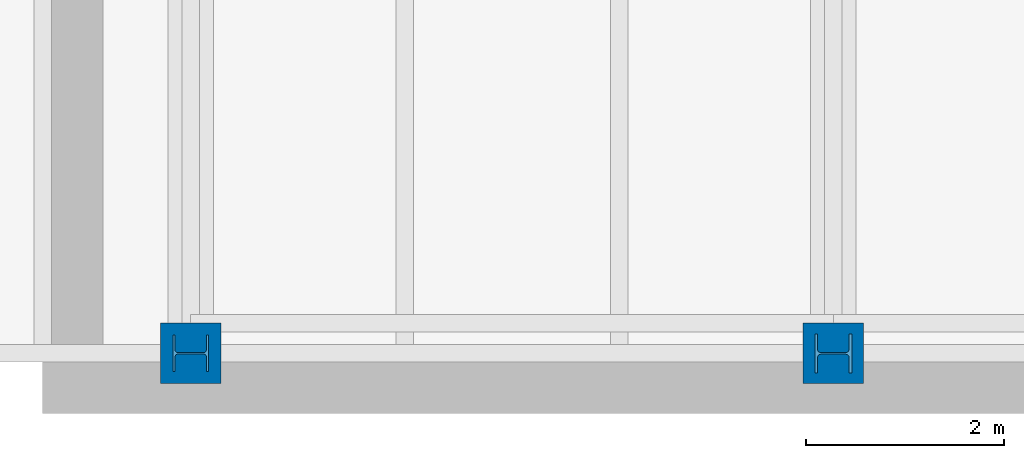
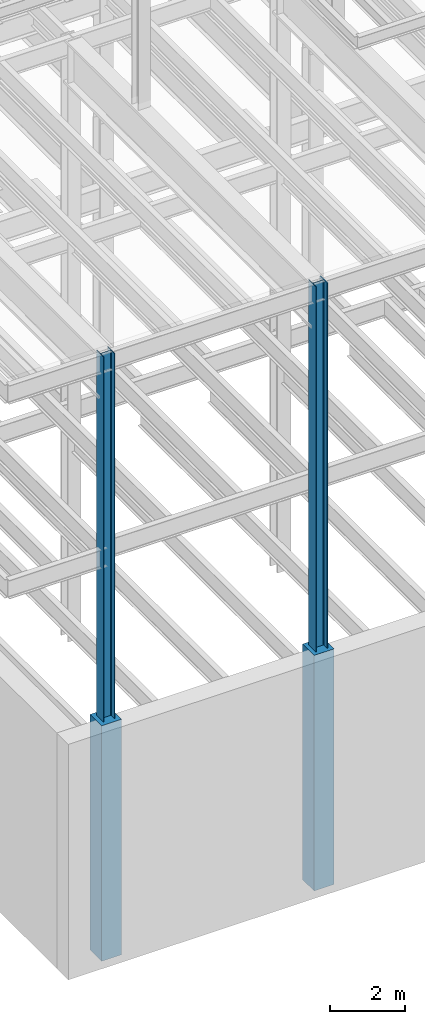
# One storey, part 1 of 150: 4 columns.
"""IFC2X3 building model written with IfcOpenShell, lengths in millimetres."""

from ifc_helpers import new_model, si_unit, frame, origin_with_axes, origin_2d_with_axis, place, context, subcontext, project, spatial, rectangle, i_section, extrude, material, type_object, element, save


model = new_model("IFC2X3")

# Units and contexts
model_context = context("Model", 3, precision=1e-05, world=origin_with_axes())
body_context = subcontext(model_context, "Body", "Model", "MODEL_VIEW")
ifc_project = project(units=[si_unit("LENGTHUNIT", "METRE", prefix="MILLI"), si_unit("AREAUNIT", "SQUARE_METRE"), si_unit("VOLUMEUNIT", "CUBIC_METRE"), si_unit("MASSUNIT", "GRAM", prefix="KILO"), si_unit("TIMEUNIT", "SECOND"), si_unit("PLANEANGLEUNIT", "RADIAN"), si_unit("SOLIDANGLEUNIT", "STERADIAN"), si_unit("THERMODYNAMICTEMPERATUREUNIT", "DEGREE_CELSIUS"), si_unit("LUMINOUSINTENSITYUNIT", "LUMEN")], contexts=[model_context])

# Site, building, storey
site_placement = place(None, origin_with_axes())
site = spatial("IfcSite", under=ifc_project, at=site_placement, CompositionType="ELEMENT")
building_placement = place(site_placement, origin_with_axes())
building = spatial("IfcBuilding", under=site, at=building_placement, Name="Undefined", CompositionType="ELEMENT")
storey_placement = place(building_placement, origin_with_axes())
storey = spatial("IfcBuildingStorey", under=building, at=storey_placement, Name="Undefined", CompositionType="ELEMENT", Elevation=0.0)

# Columns
ifc_material_1 = material(Name="STEEL/A992")
column_type_1 = type_object("IfcColumnType", Name="W14X99", PredefinedType="NOTDEFINED")
column_1_placement = place(storey_placement, frame((5283.2, 0.0, 22707.6), z_axis=(0.0, 0.0, 1.0), x_axis=(1.0, 0.0, 0.0)))
element("IfcColumn", 1, at=column_1_placement, inside=storey, type_object=column_type_1, material=ifc_material_1, Name="COLUMN", ObjectType="W14X99", context=body_context, shape_type="SweptSolid", body=[
    extrude(i_section(OverallWidth=370.84, OverallDepth=358.775, WebThickness=12.6999, FlangeThickness=19.812, FilletRadius=32.5755, at=origin_2d_with_axis()), frame((0.0, 0.0, 12877.8), z_axis=(0.0, 0.0, -1.0), x_axis=(0.0, -1.0, 0.0)), (0.0, 0.0, 1.0), 12877.8),
])
column_type_2 = type_object("IfcColumnType", Name="W14X145", PredefinedType="NOTDEFINED")
column_2_placement = place(storey_placement, frame((11785.6, 0.0, 22707.6), z_axis=(0.0, 0.0, 1.0), x_axis=(1.0, 0.0, 0.0)))
element("IfcColumn", 2, at=column_2_placement, inside=storey, type_object=column_type_2, material=ifc_material_1, Name="COLUMN", ObjectType="W14X145", context=body_context, shape_type="SweptSolid", body=[
    extrude(i_section(OverallWidth=393.7, OverallDepth=374.65, WebThickness=17.4625, FlangeThickness=27.686, FilletRadius=32.6389, at=origin_2d_with_axis()), frame((0.0, 0.0, 12877.8), z_axis=(0.0, 0.0, -1.0), x_axis=(0.0, -1.0, 0.0)), (0.0, 0.0, 1.0), 12877.8),
])
ifc_material_2 = material(Name="CONCRETE/5000")
column_type_3 = type_object("IfcColumnType", PredefinedType="NOTDEFINED")
for number, where, z_axis, x_axis, name in (
    (3, (11785.6, 0.0, 16154.4), (0.0, 0.0, 1.0), (1.0, 0.0, 0.0), "COLUMN"),
    (4, (5283.2, 0.0, 16154.4), (0.0, 0.0, 1.0), (1.0, 0.0, 0.0), "COLUMN"),
):
    element("IfcColumn", number, at=place(storey_placement, frame(where, z_axis=z_axis, x_axis=x_axis)), inside=storey, type_object=column_type_3, material=ifc_material_2, Name=name, context=body_context, shape_type="SweptSolid", body=[
        extrude(rectangle(XDim=609.6, YDim=609.6, at=origin_2d_with_axis()), frame((0.0, 0.0, 7620.0), z_axis=(0.0, 0.0, -1.0), x_axis=(0.0, -1.0, 0.0)), (0.0, 0.0, 1.0), 7620.0),
    ])

save(model, "model.ifc")
